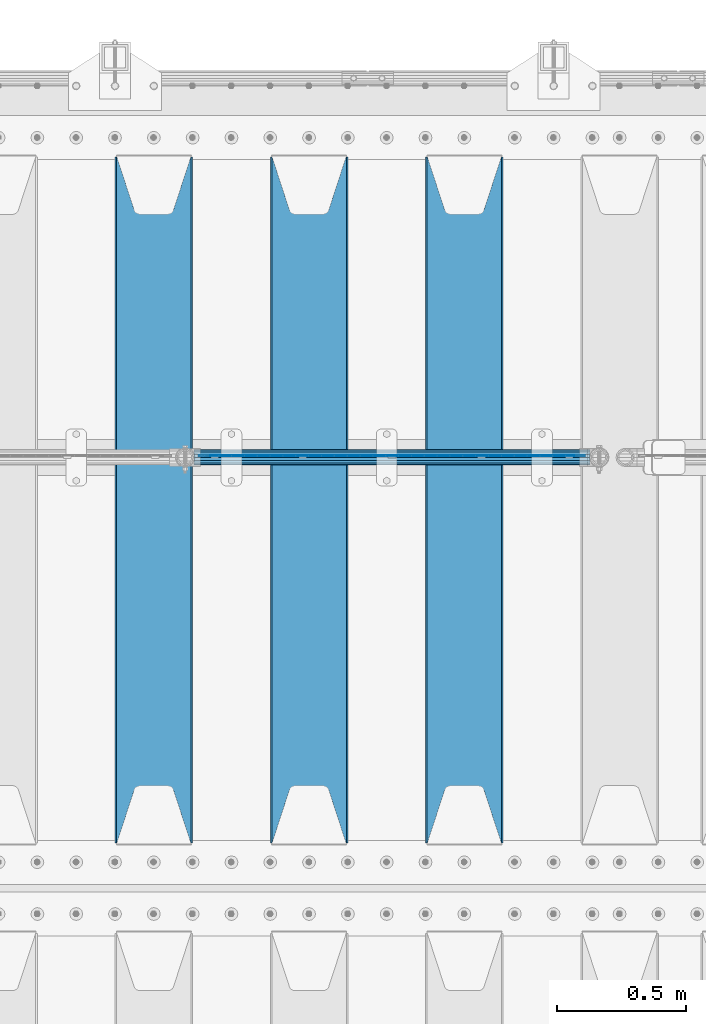
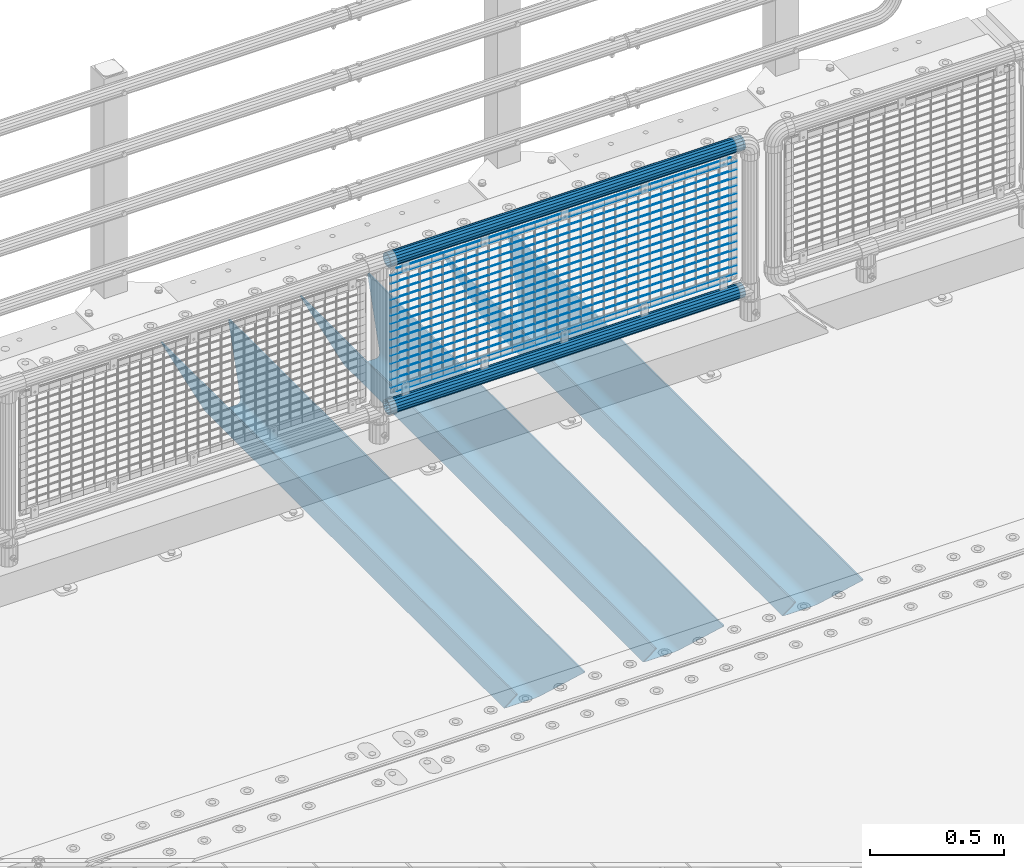
# One storey, part 127 of 257: 22 beams.
"""IFC2X3 building model written with IfcOpenShell, lengths in millimetres."""

from ifc_helpers import new_model, si_unit, frame, origin_with_axes, place, context, subcontext, project, spatial, faceted_brep, material, type_object, element, save


model = new_model("IFC2X3")

# Units and contexts
model_context = context("Model", 3, precision=1e-05, world=origin_with_axes())
body_context = subcontext(model_context, "Body", "Model", "MODEL_VIEW")
ifc_project = project(units=[si_unit("LENGTHUNIT", "METRE", prefix="MILLI"), si_unit("AREAUNIT", "SQUARE_METRE"), si_unit("VOLUMEUNIT", "CUBIC_METRE"), si_unit("MASSUNIT", "GRAM", prefix="KILO"), si_unit("TIMEUNIT", "SECOND"), si_unit("PLANEANGLEUNIT", "RADIAN"), si_unit("SOLIDANGLEUNIT", "STERADIAN"), si_unit("THERMODYNAMICTEMPERATUREUNIT", "DEGREE_CELSIUS"), si_unit("LUMINOUSINTENSITYUNIT", "LUMEN")], contexts=[model_context])

# Site, building, storey
site_placement = place(None, origin_with_axes())
site = spatial("IfcSite", under=ifc_project, at=site_placement, CompositionType="ELEMENT")
building_placement = place(site_placement, origin_with_axes())
building = spatial("IfcBuilding", under=site, at=building_placement, Name="Standard", CompositionType="ELEMENT")
storey_placement = place(building_placement, origin_with_axes())
storey = spatial("IfcBuildingStorey", under=building, at=storey_placement, Name="Undefined", CompositionType="ELEMENT", Elevation=0.0)

# Beams
ifc_material_1 = material(Name="STEEL/S355N")
beam_type_1 = type_object("IfcBeamType", PredefinedType="NOTDEFINED")
beam_1_placement = place(storey_placement, frame((56950.0, 9175.0, -115.0), z_axis=(0.0, 0.0, 1.0), x_axis=(0.0, 1.0, 0.0)))
element("IfcBeam", 1, at=beam_1_placement, inside=storey, type_object=beam_type_1, material=ifc_material_1, context=body_context, shape_type="Brep", body=[
    faceted_brep([(0.0, 150.0, 115.0), (0.0, 143.690000000002, 115.0), (2650.00000000297, 143.690000000002, 115.0), (2650.00000000297, 150.0, 115.0), (2650.00000000297, 142.059565218406, 110.0000000031), (2650.00000000297, 148.369565218403, 110.0000000031), (2441.90079219208, -80.1103600731149, -98.0992078077845), (2437.7588105432, -77.5672621345584, -102.241189456673), (2434.06523489746, -74.4080125315522, -105.934765102404), (2430.91086095089, -70.7102721255724, -109.089139048974), (2428.37322971128, -66.5649389910031, -111.626770288588), (2426.51472138055, -62.0739139532889, -113.485278619323), (2425.38102192091, -57.3475956567636, -114.618978078955), (2424.99999999987, -52.5021667386536, -115.0), (2424.99999999987, 52.5021667386536, -115.0), (2425.38102192091, 57.3475956567636, -114.618978078955), (2426.51472138055, 62.0739139532889, -113.485278619323), (2428.37322971128, 66.5649389910031, -111.626770288588), (2430.91086095089, 70.7102721255724, -109.089139048974), (2434.06523489746, 74.4080125315522, -105.934765102404), (2437.7588105432, 77.5672621345584, -102.241189456673), (2441.90079219208, 80.1103600731149, -98.0992078077846), (2446.38936140511, 81.9747917625791, -93.6106385947584), (2448.24948500409, 76.2713538057287, -91.7505149957729), (2444.62967112262, 74.76777986261, -95.3703288772456), (2441.28936334126, 72.7168944282894, -98.710636658607), (2438.31067330438, 70.1691124903809, -101.689326695487), (2435.76682334747, 67.1870637758839, -104.233176652398), (2433.72034654133, 63.8440531834931, -106.279653458539), (2432.22154950041, 60.2222587982324, -107.778450499454), (2431.30727574265, 56.4107117849126, -108.692724257221), (2430.99999999987, 52.5031078186876, -109.0), (2430.99999999987, -52.5031078186876, -109.0), (2431.30727574265, -56.4107117849126, -108.692724257221), (2432.22154950041, -60.2222587982324, -107.778450499454), (2433.72034654133, -63.8440531834931, -106.279653458539), (2435.76682334747, -67.1870637758839, -104.233176652398), (2438.31067330438, -70.1691124903809, -101.689326695487), (2441.28936334126, -72.7168944282894, -98.7106366586071), (2444.62967112262, -74.76777986261, -95.3703288772457), (2448.24948500409, -76.2713538057287, -91.7505149957729), (2650.00000000297, -142.059565218406, 110.0000000031), (2650.00000000297, -148.369565218403, 110.0000000031), (2446.38936140511, -81.9747917625791, -93.6106385947584), (2650.00000000297, -143.690000000002, 115.0), (2650.00000000297, -150.0, 115.0), (0.0, -143.690000000002, 115.0), (0.0, -150.0, 115.0), (0.0, -148.369565218258, 110.000000002662), (203.61063859742, -81.9747917625791, -93.6106385947584), (208.099207810447, -80.1103600731149, -98.0992078077845), (212.241189459335, -77.5672621345584, -102.241189456673), (215.934765105066, -74.4080125315522, -105.934765102404), (219.089139051636, -70.7102721255724, -109.089139048974), (221.626770291251, -66.5649389910031, -111.626770288588), (223.485278621985, -62.0739139532889, -113.485278619323), (224.618978081617, -57.3475956567636, -114.618978078955), (225.000000002662, -52.5021667386536, -115.0), (225.000000002662, 52.5021667386536, -115.0), (224.618978081617, 57.3475956567636, -114.618978078955), (223.485278621985, 62.0739139532889, -113.485278619323), (221.626770291251, 66.5649389910031, -111.626770288588), (219.089139051636, 70.7102721255724, -109.089139048974), (215.934765105066, 74.4080125315522, -105.934765102404), (212.241189459335, 77.5672621345584, -102.241189456673), (208.099207810447, 80.1103600731149, -98.0992078077846), (203.61063859742, 81.9747917625791, -93.6106385947584), (0.0, 148.369565218258, 110.000000002662), (0.0, 142.05956521826, 110.000000002662), (201.750514998435, 76.2713538057287, -91.7505149957729), (205.370328879908, 74.76777986261, -95.3703288772456), (208.710636661269, 72.7168944282894, -98.710636658607), (211.689326698149, 70.1691124903809, -101.689326695487), (214.233176655061, 67.1870637758839, -104.233176652398), (216.279653461201, 63.8440531834931, -106.279653458539), (217.778450502116, 60.2222587982324, -107.778450499454), (218.692724259884, 56.4107117849126, -108.692724257221), (219.000000002662, 52.5031078186876, -109.0), (219.000000002662, -52.5031078186876, -109.0), (218.692724259884, -56.4107117849126, -108.692724257221), (217.778450502116, -60.2222587982324, -107.778450499454), (216.279653461201, -63.8440531834931, -106.279653458539), (214.233176655061, -67.1870637758839, -104.233176652398), (211.689326698149, -70.1691124903809, -101.689326695487), (208.710636661269, -72.7168944282894, -98.7106366586071), (205.370328879908, -74.76777986261, -95.3703288772457), (201.750514998435, -76.2713538057287, -91.7505149957729), (0.0, -142.05956521826, 110.000000002662)], [[[0, 1, 2, 3]], [[3, 2, 4, 5]], [[6, 7, 8, 9, 10, 11, 12, 13, 14, 15, 16, 17, 18, 19, 20, 21, 22, 5, 4, 23, 24, 25, 26, 27, 28, 29, 30, 31, 32, 33, 34, 35, 36, 37, 38, 39, 40, 41, 42, 43]], [[44, 45, 42, 41]], [[46, 47, 45, 44]], [[43, 42, 45, 47, 48, 49]], [[6, 43, 49, 50]], [[7, 6, 50, 51]], [[8, 7, 51, 52]], [[9, 8, 52, 53]], [[10, 9, 53, 54]], [[11, 10, 54, 55]], [[12, 11, 55, 56]], [[13, 12, 56, 57]], [[14, 13, 57, 58]], [[15, 14, 58, 59]], [[16, 15, 59, 60]], [[17, 16, 60, 61]], [[18, 17, 61, 62]], [[19, 18, 62, 63]], [[20, 19, 63, 64]], [[21, 20, 64, 65]], [[22, 21, 65, 66]], [[0, 3, 5, 22, 66, 67]], [[1, 0, 67, 68]], [[23, 4, 2, 1, 68, 69]], [[24, 23, 69, 70]], [[25, 24, 70, 71]], [[26, 25, 71, 72]], [[27, 26, 72, 73]], [[28, 27, 73, 74]], [[29, 28, 74, 75]], [[30, 29, 75, 76]], [[31, 30, 76, 77]], [[32, 31, 77, 78]], [[33, 32, 78, 79]], [[34, 33, 79, 80]], [[35, 34, 80, 81]], [[36, 35, 81, 82]], [[37, 36, 82, 83]], [[38, 37, 83, 84]], [[39, 38, 84, 85]], [[40, 39, 85, 86]], [[46, 44, 41, 40, 86, 87]], [[47, 46, 87, 48]], [[86, 85, 84, 83, 82, 81, 80, 79, 78, 77, 76, 75, 74, 73, 72, 71, 70, 69, 68, 67, 66, 65, 64, 63, 62, 61, 60, 59, 58, 57, 56, 55, 54, 53, 52, 51, 50, 49, 48, 87]]]),
])
beam_2_placement = place(storey_placement, frame((56350.0, 9175.0, -115.0), z_axis=(0.0, 0.0, 1.0), x_axis=(0.0, 1.0, 0.0)))
element("IfcBeam", 2, at=beam_2_placement, inside=storey, type_object=beam_type_1, material=ifc_material_1, context=body_context, shape_type="Brep", body=[
    faceted_brep([(0.0, 150.0, 115.0), (0.0, 143.690000000002, 115.0), (2650.00000000297, 143.690000000002, 115.0), (2650.00000000297, 150.0, 115.0), (2650.00000000297, 142.059565218406, 110.0000000031), (2650.00000000297, 148.369565218403, 110.0000000031), (2441.90079219208, -80.1103600731149, -98.0992078077845), (2437.7588105432, -77.5672621345584, -102.241189456673), (2434.06523489746, -74.4080125315522, -105.934765102404), (2430.91086095089, -70.7102721255724, -109.089139048974), (2428.37322971128, -66.5649389910031, -111.626770288588), (2426.51472138055, -62.0739139532889, -113.485278619323), (2425.38102192091, -57.3475956567636, -114.618978078955), (2424.99999999987, -52.5021667386536, -115.0), (2424.99999999987, 52.5021667386536, -115.0), (2425.38102192091, 57.3475956567636, -114.618978078955), (2426.51472138055, 62.0739139532889, -113.485278619323), (2428.37322971128, 66.5649389910031, -111.626770288588), (2430.91086095089, 70.7102721255724, -109.089139048974), (2434.06523489746, 74.4080125315522, -105.934765102404), (2437.7588105432, 77.5672621345584, -102.241189456673), (2441.90079219208, 80.1103600731149, -98.0992078077846), (2446.38936140511, 81.9747917625791, -93.6106385947584), (2448.24948500409, 76.2713538057287, -91.7505149957729), (2444.62967112262, 74.76777986261, -95.3703288772456), (2441.28936334126, 72.7168944282894, -98.710636658607), (2438.31067330438, 70.1691124903809, -101.689326695487), (2435.76682334747, 67.1870637758839, -104.233176652398), (2433.72034654133, 63.8440531834931, -106.279653458539), (2432.22154950041, 60.2222587982324, -107.778450499454), (2431.30727574265, 56.4107117849126, -108.692724257221), (2430.99999999987, 52.5031078186876, -109.0), (2430.99999999987, -52.5031078186876, -109.0), (2431.30727574265, -56.4107117849126, -108.692724257221), (2432.22154950041, -60.2222587982324, -107.778450499454), (2433.72034654133, -63.8440531834931, -106.279653458539), (2435.76682334747, -67.1870637758839, -104.233176652398), (2438.31067330438, -70.1691124903809, -101.689326695487), (2441.28936334126, -72.7168944282894, -98.7106366586071), (2444.62967112262, -74.76777986261, -95.3703288772457), (2448.24948500409, -76.2713538057287, -91.7505149957729), (2650.00000000297, -142.059565218406, 110.0000000031), (2650.00000000297, -148.369565218403, 110.0000000031), (2446.38936140511, -81.9747917625791, -93.6106385947584), (2650.00000000297, -143.690000000002, 115.0), (2650.00000000297, -150.0, 115.0), (0.0, -143.690000000002, 115.0), (0.0, -150.0, 115.0), (0.0, -148.369565218258, 110.000000002662), (203.61063859742, -81.9747917625791, -93.6106385947584), (208.099207810447, -80.1103600731149, -98.0992078077845), (212.241189459335, -77.5672621345584, -102.241189456673), (215.934765105066, -74.4080125315522, -105.934765102404), (219.089139051636, -70.7102721255724, -109.089139048974), (221.626770291251, -66.5649389910031, -111.626770288588), (223.485278621985, -62.0739139532889, -113.485278619323), (224.618978081617, -57.3475956567636, -114.618978078955), (225.000000002662, -52.5021667386536, -115.0), (225.000000002662, 52.5021667386536, -115.0), (224.618978081617, 57.3475956567636, -114.618978078955), (223.485278621985, 62.0739139532889, -113.485278619323), (221.626770291251, 66.5649389910031, -111.626770288588), (219.089139051636, 70.7102721255724, -109.089139048974), (215.934765105066, 74.4080125315522, -105.934765102404), (212.241189459335, 77.5672621345584, -102.241189456673), (208.099207810447, 80.1103600731149, -98.0992078077846), (203.61063859742, 81.9747917625791, -93.6106385947584), (0.0, 148.369565218258, 110.000000002662), (0.0, 142.05956521826, 110.000000002662), (201.750514998435, 76.2713538057287, -91.7505149957729), (205.370328879908, 74.76777986261, -95.3703288772456), (208.710636661269, 72.7168944282894, -98.710636658607), (211.689326698149, 70.1691124903809, -101.689326695487), (214.233176655061, 67.1870637758839, -104.233176652398), (216.279653461201, 63.8440531834931, -106.279653458539), (217.778450502116, 60.2222587982324, -107.778450499454), (218.692724259884, 56.4107117849126, -108.692724257221), (219.000000002662, 52.5031078186876, -109.0), (219.000000002662, -52.5031078186876, -109.0), (218.692724259884, -56.4107117849126, -108.692724257221), (217.778450502116, -60.2222587982324, -107.778450499454), (216.279653461201, -63.8440531834931, -106.279653458539), (214.233176655061, -67.1870637758839, -104.233176652398), (211.689326698149, -70.1691124903809, -101.689326695487), (208.710636661269, -72.7168944282894, -98.7106366586071), (205.370328879908, -74.76777986261, -95.3703288772457), (201.750514998435, -76.2713538057287, -91.7505149957729), (0.0, -142.05956521826, 110.000000002662)], [[[0, 1, 2, 3]], [[3, 2, 4, 5]], [[6, 7, 8, 9, 10, 11, 12, 13, 14, 15, 16, 17, 18, 19, 20, 21, 22, 5, 4, 23, 24, 25, 26, 27, 28, 29, 30, 31, 32, 33, 34, 35, 36, 37, 38, 39, 40, 41, 42, 43]], [[44, 45, 42, 41]], [[46, 47, 45, 44]], [[43, 42, 45, 47, 48, 49]], [[6, 43, 49, 50]], [[7, 6, 50, 51]], [[8, 7, 51, 52]], [[9, 8, 52, 53]], [[10, 9, 53, 54]], [[11, 10, 54, 55]], [[12, 11, 55, 56]], [[13, 12, 56, 57]], [[14, 13, 57, 58]], [[15, 14, 58, 59]], [[16, 15, 59, 60]], [[17, 16, 60, 61]], [[18, 17, 61, 62]], [[19, 18, 62, 63]], [[20, 19, 63, 64]], [[21, 20, 64, 65]], [[22, 21, 65, 66]], [[0, 3, 5, 22, 66, 67]], [[1, 0, 67, 68]], [[23, 4, 2, 1, 68, 69]], [[24, 23, 69, 70]], [[25, 24, 70, 71]], [[26, 25, 71, 72]], [[27, 26, 72, 73]], [[28, 27, 73, 74]], [[29, 28, 74, 75]], [[30, 29, 75, 76]], [[31, 30, 76, 77]], [[32, 31, 77, 78]], [[33, 32, 78, 79]], [[34, 33, 79, 80]], [[35, 34, 80, 81]], [[36, 35, 81, 82]], [[37, 36, 82, 83]], [[38, 37, 83, 84]], [[39, 38, 84, 85]], [[40, 39, 85, 86]], [[46, 44, 41, 40, 86, 87]], [[47, 46, 87, 48]], [[86, 85, 84, 83, 82, 81, 80, 79, 78, 77, 76, 75, 74, 73, 72, 71, 70, 69, 68, 67, 66, 65, 64, 63, 62, 61, 60, 59, 58, 57, 56, 55, 54, 53, 52, 51, 50, 49, 48, 87]]]),
])
beam_3_placement = place(storey_placement, frame((55750.0, 9175.0, -115.0), z_axis=(0.0, 0.0, 1.0), x_axis=(0.0, 1.0, 0.0)))
element("IfcBeam", 3, at=beam_3_placement, inside=storey, type_object=beam_type_1, material=ifc_material_1, context=body_context, shape_type="Brep", body=[
    faceted_brep([(0.0, 150.0, 115.0), (0.0, 143.690000000002, 115.0), (2650.00000000297, 143.690000000002, 115.0), (2650.00000000297, 150.0, 115.0), (2650.00000000297, 142.059565218406, 110.0000000031), (2650.00000000297, 148.369565218403, 110.0000000031), (2441.90079219208, -80.1103600731149, -98.0992078077845), (2437.7588105432, -77.5672621345584, -102.241189456673), (2434.06523489746, -74.4080125315522, -105.934765102404), (2430.91086095089, -70.7102721255724, -109.089139048974), (2428.37322971128, -66.5649389910031, -111.626770288588), (2426.51472138055, -62.0739139532889, -113.485278619323), (2425.38102192091, -57.3475956567636, -114.618978078955), (2424.99999999987, -52.5021667386536, -115.0), (2424.99999999987, 52.5021667386536, -115.0), (2425.38102192091, 57.3475956567636, -114.618978078955), (2426.51472138055, 62.0739139532889, -113.485278619323), (2428.37322971128, 66.5649389910031, -111.626770288588), (2430.91086095089, 70.7102721255724, -109.089139048974), (2434.06523489746, 74.4080125315522, -105.934765102404), (2437.7588105432, 77.5672621345584, -102.241189456673), (2441.90079219208, 80.1103600731149, -98.0992078077846), (2446.38936140511, 81.9747917625791, -93.6106385947584), (2448.24948500409, 76.2713538057287, -91.7505149957729), (2444.62967112262, 74.76777986261, -95.3703288772456), (2441.28936334126, 72.7168944282894, -98.710636658607), (2438.31067330438, 70.1691124903809, -101.689326695487), (2435.76682334747, 67.1870637758839, -104.233176652398), (2433.72034654133, 63.8440531834931, -106.279653458539), (2432.22154950041, 60.2222587982324, -107.778450499454), (2431.30727574265, 56.4107117849126, -108.692724257221), (2430.99999999987, 52.5031078186876, -109.0), (2430.99999999987, -52.5031078186876, -109.0), (2431.30727574265, -56.4107117849126, -108.692724257221), (2432.22154950041, -60.2222587982324, -107.778450499454), (2433.72034654133, -63.8440531834931, -106.279653458539), (2435.76682334747, -67.1870637758839, -104.233176652398), (2438.31067330438, -70.1691124903809, -101.689326695487), (2441.28936334126, -72.7168944282894, -98.7106366586071), (2444.62967112262, -74.76777986261, -95.3703288772457), (2448.24948500409, -76.2713538057287, -91.7505149957729), (2650.00000000297, -142.059565218406, 110.0000000031), (2650.00000000297, -148.369565218403, 110.0000000031), (2446.38936140511, -81.9747917625791, -93.6106385947584), (2650.00000000297, -143.690000000002, 115.0), (2650.00000000297, -150.0, 115.0), (0.0, -143.690000000002, 115.0), (0.0, -150.0, 115.0), (0.0, -148.369565218258, 110.000000002662), (203.61063859742, -81.9747917625791, -93.6106385947584), (208.099207810447, -80.1103600731149, -98.0992078077845), (212.241189459335, -77.5672621345584, -102.241189456673), (215.934765105066, -74.4080125315522, -105.934765102404), (219.089139051636, -70.7102721255724, -109.089139048974), (221.626770291251, -66.5649389910031, -111.626770288588), (223.485278621985, -62.0739139532889, -113.485278619323), (224.618978081617, -57.3475956567636, -114.618978078955), (225.000000002662, -52.5021667386536, -115.0), (225.000000002662, 52.5021667386536, -115.0), (224.618978081617, 57.3475956567636, -114.618978078955), (223.485278621985, 62.0739139532889, -113.485278619323), (221.626770291251, 66.5649389910031, -111.626770288588), (219.089139051636, 70.7102721255724, -109.089139048974), (215.934765105066, 74.4080125315522, -105.934765102404), (212.241189459335, 77.5672621345584, -102.241189456673), (208.099207810447, 80.1103600731149, -98.0992078077846), (203.61063859742, 81.9747917625791, -93.6106385947584), (0.0, 148.369565218258, 110.000000002662), (0.0, 142.05956521826, 110.000000002662), (201.750514998435, 76.2713538057287, -91.7505149957729), (205.370328879908, 74.76777986261, -95.3703288772456), (208.710636661269, 72.7168944282894, -98.710636658607), (211.689326698149, 70.1691124903809, -101.689326695487), (214.233176655061, 67.1870637758839, -104.233176652398), (216.279653461201, 63.8440531834931, -106.279653458539), (217.778450502116, 60.2222587982324, -107.778450499454), (218.692724259884, 56.4107117849126, -108.692724257221), (219.000000002662, 52.5031078186876, -109.0), (219.000000002662, -52.5031078186876, -109.0), (218.692724259884, -56.4107117849126, -108.692724257221), (217.778450502116, -60.2222587982324, -107.778450499454), (216.279653461201, -63.8440531834931, -106.279653458539), (214.233176655061, -67.1870637758839, -104.233176652398), (211.689326698149, -70.1691124903809, -101.689326695487), (208.710636661269, -72.7168944282894, -98.7106366586071), (205.370328879908, -74.76777986261, -95.3703288772457), (201.750514998435, -76.2713538057287, -91.7505149957729), (0.0, -142.05956521826, 110.000000002662)], [[[0, 1, 2, 3]], [[3, 2, 4, 5]], [[6, 7, 8, 9, 10, 11, 12, 13, 14, 15, 16, 17, 18, 19, 20, 21, 22, 5, 4, 23, 24, 25, 26, 27, 28, 29, 30, 31, 32, 33, 34, 35, 36, 37, 38, 39, 40, 41, 42, 43]], [[44, 45, 42, 41]], [[46, 47, 45, 44]], [[43, 42, 45, 47, 48, 49]], [[6, 43, 49, 50]], [[7, 6, 50, 51]], [[8, 7, 51, 52]], [[9, 8, 52, 53]], [[10, 9, 53, 54]], [[11, 10, 54, 55]], [[12, 11, 55, 56]], [[13, 12, 56, 57]], [[14, 13, 57, 58]], [[15, 14, 58, 59]], [[16, 15, 59, 60]], [[17, 16, 60, 61]], [[18, 17, 61, 62]], [[19, 18, 62, 63]], [[20, 19, 63, 64]], [[21, 20, 64, 65]], [[22, 21, 65, 66]], [[0, 3, 5, 22, 66, 67]], [[1, 0, 67, 68]], [[23, 4, 2, 1, 68, 69]], [[24, 23, 69, 70]], [[25, 24, 70, 71]], [[26, 25, 71, 72]], [[27, 26, 72, 73]], [[28, 27, 73, 74]], [[29, 28, 74, 75]], [[30, 29, 75, 76]], [[31, 30, 76, 77]], [[32, 31, 77, 78]], [[33, 32, 78, 79]], [[34, 33, 79, 80]], [[35, 34, 80, 81]], [[36, 35, 81, 82]], [[37, 36, 82, 83]], [[38, 37, 83, 84]], [[39, 38, 84, 85]], [[40, 39, 85, 86]], [[46, 44, 41, 40, 86, 87]], [[47, 46, 87, 48]], [[86, 85, 84, 83, 82, 81, 80, 79, 78, 77, 76, 75, 74, 73, 72, 71, 70, 69, 68, 67, 66, 65, 64, 63, 62, 61, 60, 59, 58, 57, 56, 55, 54, 53, 52, 51, 50, 49, 48, 87]]]),
])
ifc_material_2 = material(Name="Misc_Undefined")
beam_type_2 = type_object("IfcBeamType", Name="D3", PredefinedType="NOTDEFINED")
for number, where, z_axis, x_axis in (
    (4, (55926.0, 10670.5, 851.597000000006), (0.0, 0.0, 1.0), (1.0, 0.0, 0.0)),
    (5, (55926.0, 10670.5, 669.452000000006), (0.0, 0.0, 1.0), (1.0, 0.0, 0.0)),
    (6, (55926.0, 10670.5, 523.736000000006), (0.0, 0.0, 1.0), (1.0, 0.0, 0.0)),
    (7, (55926.0, 10670.5, 487.307000000006), (0.0, 0.0, 1.0), (1.0, 0.0, 0.0)),
    (8, (55926.0, 10670.5, 705.881000000006), (0.0, 0.0, 1.0), (1.0, 0.0, 0.0)),
    (9, (55926.0, 10670.5, 596.594000000006), (0.0, 0.0, 1.0), (1.0, 0.0, 0.0)),
    (10, (55926.0, 10670.5, 450.878000000006), (0.0, 0.0, 1.0), (1.0, 0.0, 0.0)),
    (11, (55926.0, 10670.5, 815.168000000006), (0.0, 0.0, 1.0), (1.0, 0.0, 0.0)),
    (12, (55926.0, 10670.5, 888.026000000006), (0.0, 0.0, 1.0), (1.0, 0.0, 0.0)),
    (13, (55926.0, 10670.5, 778.739000000006), (0.0, 0.0, 1.0), (1.0, 0.0, 0.0)),
    (14, (55926.0, 10670.5, 742.310000000006), (0.0, 0.0, 1.0), (1.0, 0.0, 0.0)),
    (15, (55926.0, 10670.5, 633.023000000006), (0.0, 0.0, 1.0), (1.0, 0.0, 0.0)),
    (16, (55926.0, 10670.5, 560.165000000006), (0.0, 0.0, 1.0), (1.0, 0.0, 0.0)),
    (17, (55926.0, 10670.5, 414.449000000006), (0.0, 0.0, 1.0), (1.0, 0.0, 0.0)),
):
    element("IfcBeam", number, at=place(storey_placement, frame(where, z_axis=z_axis, x_axis=x_axis)), inside=storey, type_object=beam_type_2, material=ifc_material_2, ObjectType="D3", context=body_context, shape_type="Brep", body=[
        faceted_brep([(0.0, -1.5, -5.6843418860808e-14), (0.0, -0.750000000001819, -1.29903810567669), (1490.0, -0.75, -1.29903810567669), (1490.0, -1.5, 0.0), (7.27595761418343e-12, 0.749999999998181, -1.29903810567669), (1490.0, 0.75, -1.29903810567669), (0.0, 1.5, -5.6843418860808e-14), (1490.0, 1.5, 0.0), (7.27595761418343e-12, 0.749999999998181, 1.29903810567669), (1490.0, 0.75, 1.29903810567669), (0.0, -0.750000000001819, 1.29903810567669), (1490.0, -0.75, 1.29903810567669)], [[[0, 1, 2, 3]], [[1, 4, 5, 2]], [[4, 6, 7, 5]], [[6, 8, 9, 7]], [[8, 10, 11, 9]], [[10, 0, 3, 11]], [[5, 7, 9, 11, 3, 2]], [[10, 8, 6, 4, 1, 0]]]),
    ])
beam_4_placement = place(storey_placement, frame((55951.0, 10670.5, 353.020000000006), z_axis=(0.0, 0.0, 1.0), x_axis=(1.0, 0.0, 0.0)))
element("IfcBeam", 18, at=beam_4_placement, inside=storey, type_object=beam_type_2, material=ifc_material_2, ObjectType="D3", context=body_context, shape_type="Brep", body=[
    faceted_brep([(0.0, -1.5, -5.6843418860808e-14), (0.0, -0.750000000001819, -1.29903810567669), (1440.0, -0.75, -1.29903810567669), (1440.0, -1.5, 0.0), (7.27595761418343e-12, 0.749999999998181, -1.29903810567669), (1440.0, 0.75, -1.29903810567663), (0.0, 1.5, -5.6843418860808e-14), (1440.0, 1.5, 0.0), (7.27595761418343e-12, 0.749999999998181, 1.29903810567669), (1440.0, 0.75, 1.29903810567669), (0.0, -0.750000000001819, 1.29903810567669), (1440.0, -0.75, 1.29903810567669)], [[[0, 1, 2, 3]], [[1, 4, 5, 2]], [[4, 6, 7, 5]], [[6, 8, 9, 7]], [[8, 10, 11, 9]], [[10, 0, 3, 11]], [[5, 7, 9, 11, 3, 2]], [[10, 8, 6, 4, 1, 0]]]),
])
beam_5_placement = place(storey_placement, frame((55926.0, 10670.5, 378.020000000006), z_axis=(0.0, 0.0, 1.0), x_axis=(1.0, 0.0, 0.0)))
element("IfcBeam", 19, at=beam_5_placement, inside=storey, type_object=beam_type_2, material=ifc_material_2, ObjectType="D3", context=body_context, shape_type="Brep", body=[
    faceted_brep([(0.0, -1.5, -5.6843418860808e-14), (0.0, -0.750000000001819, -1.29903810567669), (1490.0, -0.75, -1.29903810567669), (1490.0, -1.5, 0.0), (7.27595761418343e-12, 0.749999999998181, -1.29903810567669), (1490.0, 0.75, -1.29903810567669), (0.0, 1.5, -5.6843418860808e-14), (1490.0, 1.5, 0.0), (7.27595761418343e-12, 0.749999999998181, 1.29903810567669), (1490.0, 0.75, 1.29903810567669), (0.0, -0.750000000001819, 1.29903810567669), (1490.0, -0.75, 1.29903810567669)], [[[0, 1, 2, 3]], [[1, 4, 5, 2]], [[4, 6, 7, 5]], [[6, 8, 9, 7]], [[8, 10, 11, 9]], [[10, 0, 3, 11]], [[5, 7, 9, 11, 3, 2]], [[10, 8, 6, 4, 1, 0]]]),
])
beam_6_placement = place(storey_placement, frame((55951.0, 10670.5, 913.020000000006), z_axis=(0.0, 0.0, 1.0), x_axis=(1.0, 0.0, 0.0)))
element("IfcBeam", 20, at=beam_6_placement, inside=storey, type_object=beam_type_2, material=ifc_material_2, ObjectType="D3", context=body_context, shape_type="Brep", body=[
    faceted_brep([(0.0, -1.5, -5.6843418860808e-14), (0.0, -0.750000000001819, -1.29903810567669), (1440.0, -0.75, -1.29903810567669), (1440.0, -1.5, 0.0), (7.27595761418343e-12, 0.749999999998181, -1.29903810567669), (1440.0, 0.75, -1.29903810567663), (0.0, 1.5, -5.6843418860808e-14), (1440.0, 1.5, 0.0), (7.27595761418343e-12, 0.749999999998181, 1.29903810567669), (1440.0, 0.75, 1.29903810567669), (0.0, -0.750000000001819, 1.29903810567669), (1440.0, -0.75, 1.29903810567669)], [[[0, 1, 2, 3]], [[1, 4, 5, 2]], [[4, 6, 7, 5]], [[6, 8, 9, 7]], [[8, 10, 11, 9]], [[10, 0, 3, 11]], [[5, 7, 9, 11, 3, 2]], [[10, 8, 6, 4, 1, 0]]]),
])
ifc_material_3 = material()
beam_type_3 = type_object("IfcBeamType", PredefinedType="NOTDEFINED")
beam_7_placement = place(storey_placement, frame((55905.85, 10664.5, 298.170000000007), z_axis=(0.0, 0.0, 1.0), x_axis=(1.0, 0.0, 0.0)))
element("IfcBeam", 21, at=beam_7_placement, inside=storey, type_object=beam_type_3, material=ifc_material_3, context=body_context, shape_type="Brep", body=[
    faceted_brep([(0.0, -25.3500000000004, 0.0), (0.0, -23.4203461491616, 9.70102501045767), (1530.0, -23.4203461491616, 9.70102501045506), (1530.0, -25.3500000000004, 0.0), (0.0, -17.9251569030785, 17.9251569030821), (1530.0, -17.9251569030785, 17.925156903079), (0.0, -9.70102501045585, 23.4203461491634), (1530.0, -9.70102501045585, 23.4203461491611), (0.0, 0.0, 25.3499999999985), (1530.0, 0.0, 25.35), (0.0, 9.70102501045585, 23.4203461491634), (1530.0, 9.70102501045585, 23.4203461491611), (0.0, 17.9251569030785, 17.9251569030821), (1530.0, 17.9251569030785, 17.925156903079), (0.0, 23.4203461491616, 9.70102501045767), (1530.0, 23.4203461491616, 9.701025010455), (0.0, 25.3500000000004, 0.0), (1530.0, 25.3500000000004, 0.0), (0.0, 23.4203461491616, -9.70102501045767), (1530.0, 23.4203461491616, -9.70102501045506), (0.0, 17.9251569030785, -17.9251569030821), (1530.0, 17.9251569030785, -17.925156903079), (0.0, 9.70102501045585, -23.4203461491634), (1530.0, 9.70102501045585, -23.4203461491611), (0.0, 0.0, -25.3499999999985), (1530.0, 0.0, -25.35), (0.0, -9.70102501045585, -23.4203461491634), (1530.0, -9.70102501045585, -23.4203461491611), (0.0, -17.9251569030785, -17.9251569030821), (1530.0, -17.9251569030785, -17.925156903079), (0.0, -23.4203461491616, -9.70102501045767), (1530.0, -23.4203461491616, -9.701025010455), (0.0, -30.1499999999996, 0.0), (0.0, -27.8549679052157, -11.5379054858058), (1530.0, -27.8549679052157, -11.5379054858075), (1530.0, -30.1499999999996, 0.0), (0.0, -21.3192694527752, -21.3192694527752), (1530.0, -21.3192694527752, -21.3192694527744), (0.0, -11.5379054858076, -27.8549679052157), (1530.0, -11.5379054858076, -27.8549679052153), (0.0, 0.0, -30.1500000000015), (1530.0, 0.0, -30.15), (0.0, 11.5379054858076, -27.8549679052157), (1530.0, 11.5379054858076, -27.8549679052153), (0.0, 21.3192694527752, -21.3192694527752), (1530.0, 21.3192694527752, -21.3192694527744), (0.0, 27.8549679052157, -11.5379054858058), (1530.0, 27.8549679052157, -11.5379054858075), (0.0, 30.1499999999996, 0.0), (1530.0, 30.1499999999996, 0.0), (0.0, 27.8549679052157, 11.5379054858058), (1530.0, 27.8549679052157, 11.5379054858075), (0.0, 21.3192694527752, 21.3192694527752), (1530.0, 21.3192694527752, 21.3192694527744), (0.0, 11.5379054858076, 27.8549679052157), (1530.0, 11.5379054858076, 27.8549679052153), (0.0, 0.0, 30.1500000000015), (1530.0, 0.0, 30.15), (0.0, -11.5379054858076, 27.8549679052157), (1530.0, -11.5379054858076, 27.8549679052153), (0.0, -21.3192694527752, 21.3192694527752), (1530.0, -21.3192694527752, 21.3192694527744), (0.0, -27.8549679052157, 11.5379054858058), (1530.0, -27.8549679052157, 11.5379054858075)], [[[0, 1, 2, 3]], [[1, 4, 5, 2]], [[4, 6, 7, 5]], [[6, 8, 9, 7]], [[8, 10, 11, 9]], [[10, 12, 13, 11]], [[12, 14, 15, 13]], [[14, 16, 17, 15]], [[16, 18, 19, 17]], [[18, 20, 21, 19]], [[20, 22, 23, 21]], [[22, 24, 25, 23]], [[24, 26, 27, 25]], [[26, 28, 29, 27]], [[28, 30, 31, 29]], [[30, 0, 3, 31]], [[32, 33, 34, 35]], [[33, 36, 37, 34]], [[36, 38, 39, 37]], [[38, 40, 41, 39]], [[40, 42, 43, 41]], [[42, 44, 45, 43]], [[44, 46, 47, 45]], [[46, 48, 49, 47]], [[48, 50, 51, 49]], [[50, 52, 53, 51]], [[52, 54, 55, 53]], [[54, 56, 57, 55]], [[56, 58, 59, 57]], [[58, 60, 61, 59]], [[60, 62, 63, 61]], [[62, 32, 35, 63]], [[37, 39, 41, 43, 45, 47, 49, 51, 53, 55, 57, 59, 61, 63, 35, 34], [5, 7, 9, 11, 13, 15, 17, 19, 21, 23, 25, 27, 29, 31, 3, 2]], [[62, 60, 58, 56, 54, 52, 50, 48, 46, 44, 42, 40, 38, 36, 33, 32], [30, 28, 26, 24, 22, 20, 18, 16, 14, 12, 10, 8, 6, 4, 1, 0]]]),
])
beam_8_placement = place(storey_placement, frame((55905.85, 10664.5, 969.850000000006), z_axis=(0.0, 0.0, 1.0), x_axis=(1.0, 0.0, 0.0)))
element("IfcBeam", 22, at=beam_8_placement, inside=storey, type_object=beam_type_3, material=ifc_material_3, context=body_context, shape_type="Brep", body=[
    faceted_brep([(0.0, -25.3500000000004, 0.0), (0.0, -23.4203461491616, 9.70102501045767), (1530.0, -23.4203461491616, 9.70102501045506), (1530.0, -25.3500000000004, 0.0), (0.0, -17.9251569030785, 17.9251569030821), (1530.0, -17.9251569030785, 17.925156903079), (0.0, -9.70102501045585, 23.4203461491634), (1530.0, -9.70102501045585, 23.4203461491611), (0.0, 0.0, 25.3499999999985), (1530.0, 0.0, 25.35), (0.0, 9.70102501045585, 23.4203461491634), (1530.0, 9.70102501045585, 23.4203461491611), (0.0, 17.9251569030785, 17.9251569030821), (1530.0, 17.9251569030785, 17.925156903079), (0.0, 23.4203461491616, 9.70102501045767), (1530.0, 23.4203461491616, 9.701025010455), (0.0, 25.3500000000004, 0.0), (1530.0, 25.3500000000004, 0.0), (0.0, 23.4203461491616, -9.70102501045767), (1530.0, 23.4203461491616, -9.70102501045506), (0.0, 17.9251569030785, -17.9251569030821), (1530.0, 17.9251569030785, -17.925156903079), (0.0, 9.70102501045585, -23.4203461491634), (1530.0, 9.70102501045585, -23.4203461491611), (0.0, 0.0, -25.3499999999985), (1530.0, 0.0, -25.35), (0.0, -9.70102501045585, -23.4203461491634), (1530.0, -9.70102501045585, -23.4203461491611), (0.0, -17.9251569030785, -17.9251569030821), (1530.0, -17.9251569030785, -17.925156903079), (0.0, -23.4203461491616, -9.70102501045767), (1530.0, -23.4203461491616, -9.701025010455), (0.0, -30.1499999999996, 0.0), (0.0, -27.8549679052157, -11.5379054858058), (1530.0, -27.8549679052157, -11.5379054858075), (1530.0, -30.1499999999996, 0.0), (0.0, -21.3192694527752, -21.3192694527752), (1530.0, -21.3192694527752, -21.3192694527744), (0.0, -11.5379054858076, -27.8549679052157), (1530.0, -11.5379054858076, -27.8549679052153), (0.0, 0.0, -30.1500000000015), (1530.0, 0.0, -30.15), (0.0, 11.5379054858076, -27.8549679052157), (1530.0, 11.5379054858076, -27.8549679052153), (0.0, 21.3192694527752, -21.3192694527752), (1530.0, 21.3192694527752, -21.3192694527744), (0.0, 27.8549679052157, -11.5379054858058), (1530.0, 27.8549679052157, -11.5379054858075), (0.0, 30.1499999999996, 0.0), (1530.0, 30.1499999999996, 0.0), (0.0, 27.8549679052157, 11.5379054858058), (1530.0, 27.8549679052157, 11.5379054858075), (0.0, 21.3192694527752, 21.3192694527752), (1530.0, 21.3192694527752, 21.3192694527744), (0.0, 11.5379054858076, 27.8549679052157), (1530.0, 11.5379054858076, 27.8549679052153), (0.0, 0.0, 30.1500000000015), (1530.0, 0.0, 30.15), (0.0, -11.5379054858076, 27.8549679052157), (1530.0, -11.5379054858076, 27.8549679052153), (0.0, -21.3192694527752, 21.3192694527752), (1530.0, -21.3192694527752, 21.3192694527744), (0.0, -27.8549679052157, 11.5379054858058), (1530.0, -27.8549679052157, 11.5379054858075)], [[[0, 1, 2, 3]], [[1, 4, 5, 2]], [[4, 6, 7, 5]], [[6, 8, 9, 7]], [[8, 10, 11, 9]], [[10, 12, 13, 11]], [[12, 14, 15, 13]], [[14, 16, 17, 15]], [[16, 18, 19, 17]], [[18, 20, 21, 19]], [[20, 22, 23, 21]], [[22, 24, 25, 23]], [[24, 26, 27, 25]], [[26, 28, 29, 27]], [[28, 30, 31, 29]], [[30, 0, 3, 31]], [[32, 33, 34, 35]], [[33, 36, 37, 34]], [[36, 38, 39, 37]], [[38, 40, 41, 39]], [[40, 42, 43, 41]], [[42, 44, 45, 43]], [[44, 46, 47, 45]], [[46, 48, 49, 47]], [[48, 50, 51, 49]], [[50, 52, 53, 51]], [[52, 54, 55, 53]], [[54, 56, 57, 55]], [[56, 58, 59, 57]], [[58, 60, 61, 59]], [[60, 62, 63, 61]], [[62, 32, 35, 63]], [[37, 39, 41, 43, 45, 47, 49, 51, 53, 55, 57, 59, 61, 63, 35, 34], [5, 7, 9, 11, 13, 15, 17, 19, 21, 23, 25, 27, 29, 31, 3, 2]], [[62, 60, 58, 56, 54, 52, 50, 48, 46, 44, 42, 40, 38, 36, 33, 32], [30, 28, 26, 24, 22, 20, 18, 16, 14, 12, 10, 8, 6, 4, 1, 0]]]),
])

save(model, "model.ifc")
